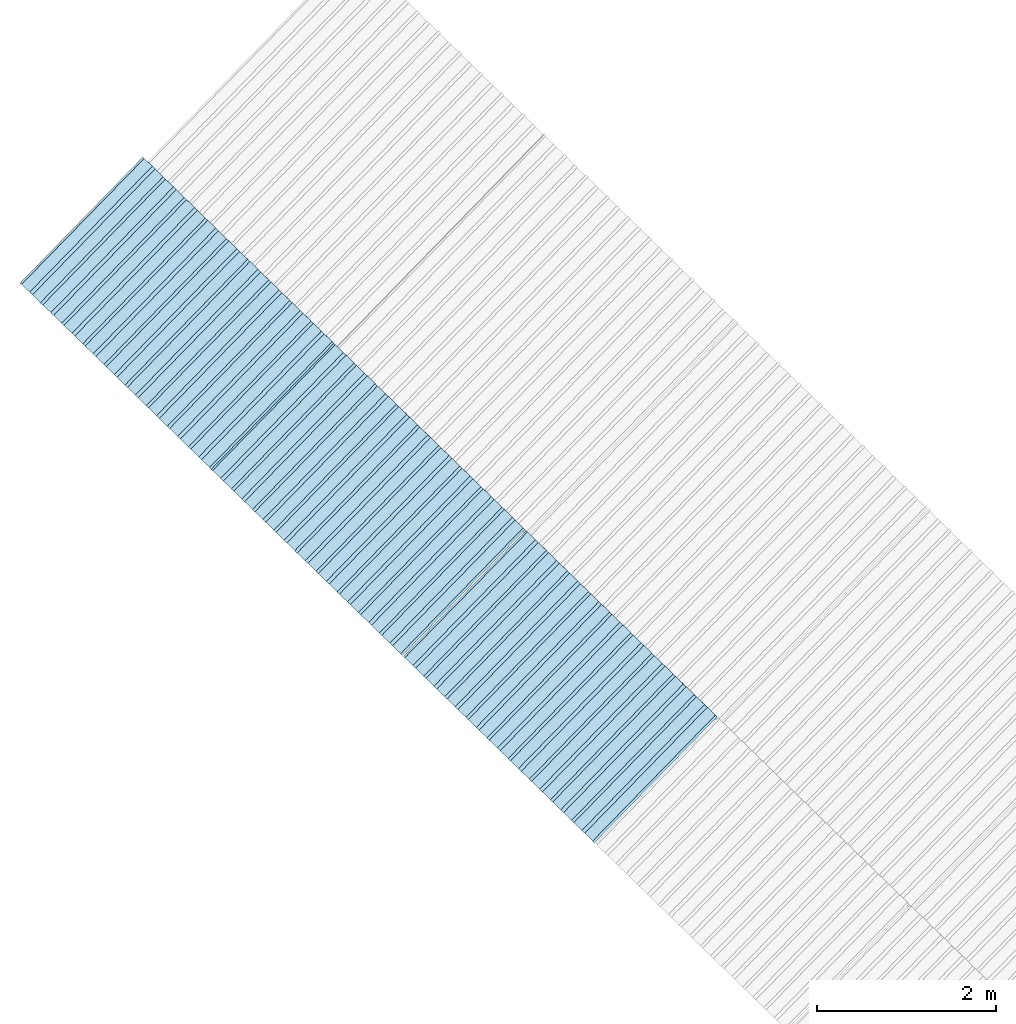
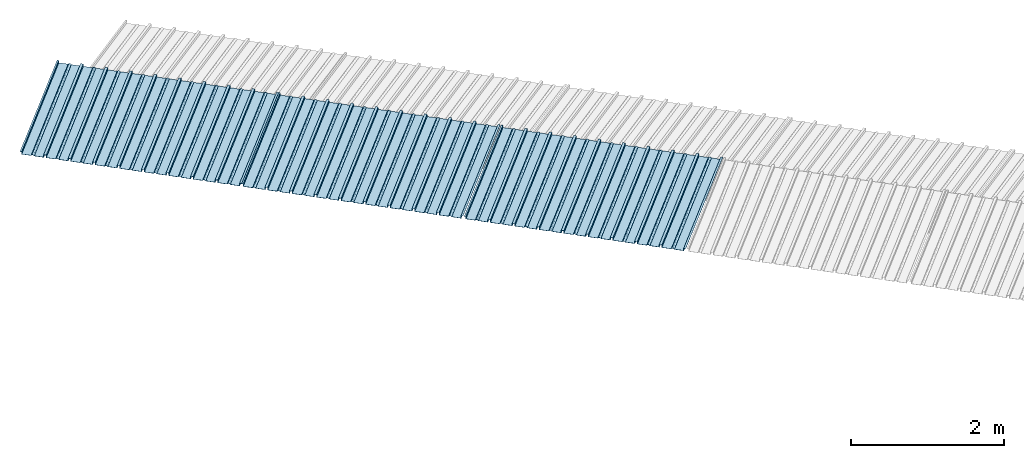
# One storey, part 6 of 8: 3 plates, 1 element without a shape of its own.
"""IFC4 building model written with IfcOpenShell, lengths in metres."""

from ifc_helpers import new_model, entity, si_unit, converted_unit, direction, frame, origin, place, context, subcontext, project, spatial, line, arc, indexed_curve, outline, extrude, source, transform, mapped, material, type_object, type_shapes, element, aggregate, save


model = new_model("IFC4")

# Units and contexts
model_context = context("Model", 3, precision=1e-05, world=origin(), true_north=direction((6.123233995736766e-17, 1.0)))
body_context = subcontext(model_context, "Body", "Model", "MODEL_VIEW")
ifc_project = project(units=[si_unit("LENGTHUNIT", "METRE"), si_unit("AREAUNIT", "SQUARE_METRE"), si_unit("VOLUMEUNIT", "CUBIC_METRE"), converted_unit("PLANEANGLEUNIT", "DEGREE", entity("IfcPlaneAngleMeasure", 0.017453292519943278), si_unit("PLANEANGLEUNIT", "RADIAN"), dimensions=[0, 0, 0, 0, 0, 0, 0])], contexts=[model_context])

# Site, building, storey
site_placement = place(None, frame((0.0, 0.0, 0.0), z_axis=(0.0, 0.0, 1.0), x_axis=(0.7160934825303189, -0.6980043870045516, 0.0)))
site = spatial("IfcSite", under=ifc_project, at=site_placement, CompositionType="ELEMENT")
building_placement = place(site_placement, origin())
building = spatial("IfcBuilding", under=site, at=building_placement, CompositionType="ELEMENT")
storey_placement = place(building_placement, frame((0.0, 0.0, -1.24)))
storey = spatial("IfcBuildingStorey", under=building, at=storey_placement, Name="Livello 5", CompositionType="ELEMENT", Elevation=-1.24)

# Roof, plates
curtain_wall_type = type_object("IfcCurtainWallType", Name="Vetrata Copertura 2", PredefinedType="NOTDEFINED")
roof_placement = place(storey_placement, frame((0.0, 0.0, 1.24)))
roof = element("IfcRoof", 1, at=roof_placement, inside=storey, type_object=curtain_wall_type, Name="Vetrata Copertura 2", ObjectType="Vetrata Copertura 2", PredefinedType="SHED_ROOF")
ifc_material = material(Name="Default")
plate_type_1 = type_object("IfcPlateType", Name="Pannello copertura:Pannello copertura", PredefinedType="CURTAIN_PANEL", material=ifc_material)
shared_shape_1 = source(origin(), body_context, "Body", "SweptSolid", [
    extrude(outline(indexed_curve([(1.339910560042256, -0.015785714285718594), (1.4699105600422562, -0.015785714285719003), (1.4699105600422562, 0.024214285714281004), (1.494919197675959, 0.02421428571428092), (1.494919197675959, 0.027214285714280917), (1.466910560042256, 0.027214285714281014), (1.466910560042256, -0.012785714285718995), (1.3417510978483753, -0.012785714285718492), (1.3199105600422556, 4.9134324369942785e-05), (1.2980700222361363, -0.012785714285718328), (1.1729105600422558, -0.01278571428571804), (1.1729105600422558, 0.02721428571428197), (1.136910560042256, 0.027214285714282097), (1.136910560042256, -0.012785714285717937), (1.0117510978483748, -0.01278571428571754), (0.9899105600422554, 4.913432437100935e-05), (0.968070022236136, -0.01278571428571726), (0.8429105600422558, -0.012785714285716971), (0.842910560042256, 0.027214285714283023), (0.8069105600422554, 0.027214285714283144), (0.8069105600422554, -0.01278571428571687), (0.6817510978483748, -0.012785714285716475), (0.6599105600422555, 4.9134324372075926e-05), (0.6380700222361361, -0.012785714285716196), (0.5129105600422553, -0.012785714285715915), (0.5129105600422554, 0.027214285714284105), (0.47691056004225557, 0.027214285714284227), (0.47691056004225557, -0.012785714285715804), (0.3517510978483749, -0.012785714285715427), (0.32991056004225544, 4.9134324373142496e-05), (0.3080700222361361, -0.012785714285715127), (0.18291056004225528, -0.012785714285714848), (0.18291056004225553, 0.027214285714285157), (0.1469105600422553, 0.02721428571428528), (0.14691056004225533, -0.012785714285714738), (0.021751097848374697, -0.01278571428571434), (-8.943995774469983e-05, 4.913432437420907e-05), (-0.021929977763864118, -0.01278571428571406), (-0.1470894399577447, -0.012785714285713783), (-0.14708943995774473, 0.02721428571428624), (-0.18308943995774493, 0.027214285714286364), (-0.1830894399577449, -0.012785714285713672), (-0.30824890215162537, -0.012785714285713215), (-0.33008943995774487, 4.9134324375275644e-05), (-0.3519299777638641, -0.012785714285712995), (-0.47708943995774494, -0.012785714285712714), (-0.4770894399577447, 0.02721428571428729), (-0.5130894399577449, 0.02721428571428741), (-0.5130894399577449, -0.012785714285712603), (-0.6382489021516256, -0.012785714285712207), (-0.6600894399577448, 4.9134324376342214e-05), (-0.6819299777638644, -0.012785714285711926), (-0.8070894399577453, -0.012785714285711647), (-0.807089439957745, 0.027214285714288373), (-0.843089439957745, 0.027214285714288494), (-0.8430894399577447, -0.012785714285711538), (-0.968248902151626, -0.012785714285711083), (-0.9900894399577453, 4.9134324377408785e-05), (-1.0119299777638646, -0.012785714285710861), (-1.1370894399577456, -0.012785714285710582), (-1.1370894399577451, 0.02721428571428942), (-1.1730894399577452, 0.027214285714289545), (-1.1730894399577454, -0.012785714285710473), (-1.2982489021516257, -0.012785714285710093), (-1.3200894399577452, 4.9134324378475355e-05), (-1.3419299777638647, -0.012785714285709794), (-1.4670894399577457, -0.012785714285709513), (-1.4670894399577454, 0.027214285714290503), (-1.490089439957745, 0.027214285714290586), (-1.490089439957745, 0.024214285714290556), (-1.4700894399577447, 0.02421428571429049), (-1.4700894399577449, -0.015785714285709514), (-1.3400894399577452, -0.015785714285709924), (-1.3200894399577452, -0.0029508656756215236), (-1.3000894399577452, -0.015785714285710063), (-1.170089439957745, -0.015785714285710472), (-1.1700894399577453, 0.024214285714289543), (-1.140089439957745, 0.02421428571428944), (-1.1400894399577455, -0.015785714285710583), (-1.0100894399577454, -0.015785714285710992), (-0.9900894399577453, -0.00295086567562259), (-0.9700894399577453, -0.015785714285711128), (-0.8400894399577448, -0.01578571428571154), (-0.8400894399577451, 0.024214285714288453), (-0.8100894399577452, 0.024214285714288356), (-0.8100894399577452, -0.015785714285711648), (-0.6800894399577451, -0.015785714285712012), (-0.6600894399577448, -0.0029508656756236573), (-0.6400894399577448, -0.015785714285712196), (-0.5100894399577451, -0.015785714285712606), (-0.5100894399577451, 0.024214285714287406), (-0.4800894399577449, 0.024214285714287305), (-0.4800894399577449, -0.015785714285712713), (-0.350089439957745, -0.01578571428571316), (-0.33008943995774487, -0.0029508656756247237), (-0.31008943995774485, -0.01578571428571326), (-0.1800894399577448, -0.015785714285713674), (-0.1800894399577448, 0.024214285714286323), (-0.1500894399577446, 0.02421428571428622), (-0.15008943995774485, -0.015785714285713782), (-0.020089439957744877, -0.015785714285714264), (-8.943995774473269e-05, -0.00295086567562579), (0.01991056004225521, -0.015785714285714323), (0.14991056004225545, -0.01578571428571474), (0.14991056004225542, 0.024214285714285272), (0.17991056004225567, 0.02421428571428517), (0.1799105600422554, -0.01578571428571485), (0.30991056004225526, -0.01578571428571532), (0.32991056004225544, -0.0029508656756268565), (0.3499105600422554, -0.015785714285715395), (0.47991056004225535, -0.015785714285715804), (0.47991056004225535, 0.02421428571428419), (0.5099105600422553, 0.02421428571428409), (0.5099105600422552, -0.015785714285715916), (0.6399105600422554, -0.015785714285716325), (0.6599105600422555, -0.002950865675627923), (0.6799105600422555, -0.01578571428571646), (0.8099105600422557, -0.015785714285716873), (0.8099105600422557, 0.02421428571428314), (0.8399105600422555, 0.02421428571428304), (0.8399105600422554, -0.015785714285716974), (0.9699105600422554, -0.015785714285717393), (0.9899105600422554, -0.0029508656756289894), (1.0099105600422555, -0.01578571428571753), (1.1399105600422557, -0.015785714285717938), (1.1399105600422557, 0.024214285714282077), (1.169910560042256, 0.024214285714281972), (1.1699105600422557, -0.01578571428571804), (1.2999105600422558, -0.01578571428571846), (1.3199105600422558, -0.0029508656756300567)], segments=[line(1, 2, 3, 4, 5, 6, 7, 8), arc(8, 9, 10), line(10, 11, 12, 13, 14, 15), arc(15, 16, 17), line(17, 18, 19, 20, 21, 22), arc(22, 23, 24), line(24, 25, 26, 27, 28, 29), arc(29, 30, 31), line(31, 32, 33, 34, 35, 36), arc(36, 37, 38), line(38, 39, 40, 41, 42, 43), arc(43, 44, 45), line(45, 46, 47, 48, 49, 50), arc(50, 51, 52), line(52, 53, 54, 55, 56, 57), arc(57, 58, 59), line(59, 60, 61, 62, 63, 64), arc(64, 65, 66), line(66, 67, 68, 69, 70, 71, 72, 73), arc(73, 74, 75), line(75, 76, 77, 78, 79, 80), arc(80, 81, 82), line(82, 83, 84, 85, 86, 87), arc(87, 88, 89), line(89, 90, 91, 92, 93, 94), arc(94, 95, 96), line(96, 97, 98, 99, 100, 101), arc(101, 102, 103), line(103, 104, 105, 106, 107, 108), arc(108, 109, 110), line(110, 111, 112, 113, 114, 115), arc(115, 116, 117), line(117, 118, 119, 120, 121, 122), arc(122, 123, 124), line(124, 125, 126, 127, 128, 129), arc(129, 130, 1)], self_intersect=False)), frame((8.080232403624576e-05, -0.015785714285719014, 0.0), z_axis=(0.0, 0.0, -1.0), x_axis=(1.0, 0.0, 0.0)), (0.0, 0.0, -1.0), 1.9691142879617602),
])
type_shapes(plate_type_1, [shared_shape_1])
plate_1_placement = place(roof_placement, frame((-26.21463516875178, -6.922854376535778, -1.0800000000000003), z_axis=(0.0, 0.9980594686585702, 0.0622679453729828), x_axis=(1.0, 0.0, 0.0)))
plate_1 = element("IfcPlate", 2, at=plate_1_placement, type_object=plate_type_1, material=ifc_material, Name="Pannello copertura:Pannello copertura", ObjectType="Pannello copertura:Pannello copertura", PredefinedType="CURTAIN_PANEL", context=body_context, shape_type="MappedRepresentation", body=[
    mapped(shared_shape_1, transform((0.0, 0.0, 0.0), scale=1.0)),
])
plate_type_2 = type_object("IfcPlateType", Name="Pannello copertura:Pannello copertura", PredefinedType="CURTAIN_PANEL", material=ifc_material)
shared_shape_2 = source(origin(), body_context, "Body", "SweptSolid", [
    extrude(outline(indexed_curve([(1.339910560042256, -0.015785714285718594), (1.4699105600422562, -0.015785714285719003), (1.4699105600422562, 0.024214285714281004), (1.494919197675959, 0.02421428571428092), (1.494919197675959, 0.027214285714280917), (1.466910560042256, 0.027214285714281014), (1.466910560042256, -0.012785714285718995), (1.3417510978483753, -0.012785714285718492), (1.3199105600422556, 4.9134324369942785e-05), (1.2980700222361363, -0.012785714285718328), (1.1729105600422558, -0.01278571428571804), (1.1729105600422558, 0.02721428571428197), (1.136910560042256, 0.027214285714282097), (1.136910560042256, -0.012785714285717937), (1.0117510978483748, -0.01278571428571754), (0.9899105600422554, 4.913432437100935e-05), (0.968070022236136, -0.01278571428571726), (0.8429105600422558, -0.012785714285716971), (0.842910560042256, 0.027214285714283023), (0.8069105600422554, 0.027214285714283144), (0.8069105600422554, -0.01278571428571687), (0.6817510978483748, -0.012785714285716475), (0.6599105600422555, 4.9134324372075926e-05), (0.6380700222361361, -0.012785714285716196), (0.5129105600422553, -0.012785714285715915), (0.5129105600422554, 0.027214285714284105), (0.47691056004225557, 0.027214285714284227), (0.47691056004225557, -0.012785714285715804), (0.3517510978483749, -0.012785714285715427), (0.32991056004225544, 4.9134324373142496e-05), (0.3080700222361361, -0.012785714285715127), (0.18291056004225528, -0.012785714285714848), (0.18291056004225553, 0.027214285714285157), (0.1469105600422553, 0.02721428571428528), (0.14691056004225533, -0.012785714285714738), (0.021751097848374697, -0.01278571428571434), (-8.943995774469983e-05, 4.913432437420907e-05), (-0.021929977763864118, -0.01278571428571406), (-0.1470894399577447, -0.012785714285713783), (-0.14708943995774473, 0.02721428571428624), (-0.18308943995774493, 0.027214285714286364), (-0.1830894399577449, -0.012785714285713672), (-0.30824890215162537, -0.012785714285713215), (-0.33008943995774487, 4.9134324375275644e-05), (-0.3519299777638641, -0.012785714285712995), (-0.47708943995774494, -0.012785714285712714), (-0.4770894399577447, 0.02721428571428729), (-0.5130894399577449, 0.02721428571428741), (-0.5130894399577449, -0.012785714285712603), (-0.6382489021516256, -0.012785714285712207), (-0.6600894399577448, 4.9134324376342214e-05), (-0.6819299777638644, -0.012785714285711926), (-0.8070894399577453, -0.012785714285711647), (-0.807089439957745, 0.027214285714288373), (-0.843089439957745, 0.027214285714288494), (-0.8430894399577447, -0.012785714285711538), (-0.968248902151626, -0.012785714285711083), (-0.9900894399577453, 4.9134324377408785e-05), (-1.0119299777638646, -0.012785714285710861), (-1.1370894399577456, -0.012785714285710582), (-1.1370894399577451, 0.02721428571428942), (-1.1730894399577452, 0.027214285714289545), (-1.1730894399577454, -0.012785714285710473), (-1.2982489021516257, -0.012785714285710093), (-1.3200894399577452, 4.9134324378475355e-05), (-1.3419299777638647, -0.012785714285709794), (-1.4670894399577457, -0.012785714285709513), (-1.4670894399577454, 0.027214285714290503), (-1.490089439957745, 0.027214285714290586), (-1.490089439957745, 0.024214285714290556), (-1.4700894399577447, 0.02421428571429049), (-1.4700894399577449, -0.015785714285709514), (-1.3400894399577452, -0.015785714285709924), (-1.3200894399577452, -0.0029508656756215236), (-1.3000894399577452, -0.015785714285710063), (-1.170089439957745, -0.015785714285710472), (-1.1700894399577453, 0.024214285714289543), (-1.140089439957745, 0.02421428571428944), (-1.1400894399577455, -0.015785714285710583), (-1.0100894399577454, -0.015785714285710992), (-0.9900894399577453, -0.00295086567562259), (-0.9700894399577453, -0.015785714285711128), (-0.8400894399577448, -0.01578571428571154), (-0.8400894399577451, 0.024214285714288453), (-0.8100894399577452, 0.024214285714288356), (-0.8100894399577452, -0.015785714285711648), (-0.6800894399577451, -0.015785714285712012), (-0.6600894399577448, -0.0029508656756236573), (-0.6400894399577448, -0.015785714285712196), (-0.5100894399577451, -0.015785714285712606), (-0.5100894399577451, 0.024214285714287406), (-0.4800894399577449, 0.024214285714287305), (-0.4800894399577449, -0.015785714285712713), (-0.350089439957745, -0.01578571428571316), (-0.33008943995774487, -0.0029508656756247237), (-0.31008943995774485, -0.01578571428571326), (-0.1800894399577448, -0.015785714285713674), (-0.1800894399577448, 0.024214285714286323), (-0.1500894399577446, 0.02421428571428622), (-0.15008943995774485, -0.015785714285713782), (-0.020089439957744877, -0.015785714285714264), (-8.943995774473269e-05, -0.00295086567562579), (0.01991056004225521, -0.015785714285714323), (0.14991056004225545, -0.01578571428571474), (0.14991056004225542, 0.024214285714285272), (0.17991056004225567, 0.02421428571428517), (0.1799105600422554, -0.01578571428571485), (0.30991056004225526, -0.01578571428571532), (0.32991056004225544, -0.0029508656756268565), (0.3499105600422554, -0.015785714285715395), (0.47991056004225535, -0.015785714285715804), (0.47991056004225535, 0.02421428571428419), (0.5099105600422553, 0.02421428571428409), (0.5099105600422552, -0.015785714285715916), (0.6399105600422554, -0.015785714285716325), (0.6599105600422555, -0.002950865675627923), (0.6799105600422555, -0.01578571428571646), (0.8099105600422557, -0.015785714285716873), (0.8099105600422557, 0.02421428571428314), (0.8399105600422555, 0.02421428571428304), (0.8399105600422554, -0.015785714285716974), (0.9699105600422554, -0.015785714285717393), (0.9899105600422554, -0.0029508656756289894), (1.0099105600422555, -0.01578571428571753), (1.1399105600422557, -0.015785714285717938), (1.1399105600422557, 0.024214285714282077), (1.169910560042256, 0.024214285714281972), (1.1699105600422557, -0.01578571428571804), (1.2999105600422558, -0.01578571428571846), (1.3199105600422558, -0.0029508656756300567)], segments=[line(1, 2, 3, 4, 5, 6, 7, 8), arc(8, 9, 10), line(10, 11, 12, 13, 14, 15), arc(15, 16, 17), line(17, 18, 19, 20, 21, 22), arc(22, 23, 24), line(24, 25, 26, 27, 28, 29), arc(29, 30, 31), line(31, 32, 33, 34, 35, 36), arc(36, 37, 38), line(38, 39, 40, 41, 42, 43), arc(43, 44, 45), line(45, 46, 47, 48, 49, 50), arc(50, 51, 52), line(52, 53, 54, 55, 56, 57), arc(57, 58, 59), line(59, 60, 61, 62, 63, 64), arc(64, 65, 66), line(66, 67, 68, 69, 70, 71, 72, 73), arc(73, 74, 75), line(75, 76, 77, 78, 79, 80), arc(80, 81, 82), line(82, 83, 84, 85, 86, 87), arc(87, 88, 89), line(89, 90, 91, 92, 93, 94), arc(94, 95, 96), line(96, 97, 98, 99, 100, 101), arc(101, 102, 103), line(103, 104, 105, 106, 107, 108), arc(108, 109, 110), line(110, 111, 112, 113, 114, 115), arc(115, 116, 117), line(117, 118, 119, 120, 121, 122), arc(122, 123, 124), line(124, 125, 126, 127, 128, 129), arc(129, 130, 1)], self_intersect=False)), frame((8.080232403624576e-05, -0.015785714285719014, 0.0), z_axis=(0.0, 0.0, -1.0), x_axis=(1.0, 0.0, 0.0)), (0.0, 0.0, -1.0), 1.9691142879617602),
])
type_shapes(plate_type_2, [shared_shape_2])
plate_2_placement = place(roof_placement, frame((-23.23213518620344, -6.922854376535778, -1.0800000000000003), z_axis=(0.0, 0.9980594686585702, 0.0622679453729828), x_axis=(1.0, 0.0, 0.0)))
plate_2 = element("IfcPlate", 3, at=plate_2_placement, type_object=plate_type_2, material=ifc_material, Name="Pannello copertura:Pannello copertura", ObjectType="Pannello copertura:Pannello copertura", PredefinedType="CURTAIN_PANEL", context=body_context, shape_type="MappedRepresentation", body=[
    mapped(shared_shape_2, transform((0.0, 0.0, 0.0), scale=1.0)),
])
plate_type_3 = type_object("IfcPlateType", Name="Pannello copertura:Pannello copertura", PredefinedType="CURTAIN_PANEL", material=ifc_material)
shared_shape_3 = source(origin(), body_context, "Body", "SweptSolid", [
    extrude(outline(indexed_curve([(1.339910560042256, -0.015785714285718594), (1.4699105600422562, -0.015785714285719003), (1.4699105600422562, 0.024214285714281004), (1.494919197675959, 0.02421428571428092), (1.494919197675959, 0.027214285714280917), (1.466910560042256, 0.027214285714281014), (1.466910560042256, -0.012785714285718995), (1.3417510978483753, -0.012785714285718492), (1.3199105600422556, 4.9134324369942785e-05), (1.2980700222361363, -0.012785714285718328), (1.1729105600422558, -0.01278571428571804), (1.1729105600422558, 0.02721428571428197), (1.136910560042256, 0.027214285714282097), (1.136910560042256, -0.012785714285717937), (1.0117510978483748, -0.01278571428571754), (0.9899105600422554, 4.913432437100935e-05), (0.968070022236136, -0.01278571428571726), (0.8429105600422558, -0.012785714285716971), (0.842910560042256, 0.027214285714283023), (0.8069105600422554, 0.027214285714283144), (0.8069105600422554, -0.01278571428571687), (0.6817510978483748, -0.012785714285716475), (0.6599105600422555, 4.9134324372075926e-05), (0.6380700222361361, -0.012785714285716196), (0.5129105600422553, -0.012785714285715915), (0.5129105600422554, 0.027214285714284105), (0.47691056004225557, 0.027214285714284227), (0.47691056004225557, -0.012785714285715804), (0.3517510978483749, -0.012785714285715427), (0.32991056004225544, 4.9134324373142496e-05), (0.3080700222361361, -0.012785714285715127), (0.18291056004225528, -0.012785714285714848), (0.18291056004225553, 0.027214285714285157), (0.1469105600422553, 0.02721428571428528), (0.14691056004225533, -0.012785714285714738), (0.021751097848374697, -0.01278571428571434), (-8.943995774469983e-05, 4.913432437420907e-05), (-0.021929977763864118, -0.01278571428571406), (-0.1470894399577447, -0.012785714285713783), (-0.14708943995774473, 0.02721428571428624), (-0.18308943995774493, 0.027214285714286364), (-0.1830894399577449, -0.012785714285713672), (-0.30824890215162537, -0.012785714285713215), (-0.33008943995774487, 4.9134324375275644e-05), (-0.3519299777638641, -0.012785714285712995), (-0.47708943995774494, -0.012785714285712714), (-0.4770894399577447, 0.02721428571428729), (-0.5130894399577449, 0.02721428571428741), (-0.5130894399577449, -0.012785714285712603), (-0.6382489021516256, -0.012785714285712207), (-0.6600894399577448, 4.9134324376342214e-05), (-0.6819299777638644, -0.012785714285711926), (-0.8070894399577453, -0.012785714285711647), (-0.807089439957745, 0.027214285714288373), (-0.843089439957745, 0.027214285714288494), (-0.8430894399577447, -0.012785714285711538), (-0.968248902151626, -0.012785714285711083), (-0.9900894399577453, 4.9134324377408785e-05), (-1.0119299777638646, -0.012785714285710861), (-1.1370894399577456, -0.012785714285710582), (-1.1370894399577451, 0.02721428571428942), (-1.1730894399577452, 0.027214285714289545), (-1.1730894399577454, -0.012785714285710473), (-1.2982489021516257, -0.012785714285710093), (-1.3200894399577452, 4.9134324378475355e-05), (-1.3419299777638647, -0.012785714285709794), (-1.4670894399577457, -0.012785714285709513), (-1.4670894399577454, 0.027214285714290503), (-1.490089439957745, 0.027214285714290586), (-1.490089439957745, 0.024214285714290556), (-1.4700894399577447, 0.02421428571429049), (-1.4700894399577449, -0.015785714285709514), (-1.3400894399577452, -0.015785714285709924), (-1.3200894399577452, -0.0029508656756215236), (-1.3000894399577452, -0.015785714285710063), (-1.170089439957745, -0.015785714285710472), (-1.1700894399577453, 0.024214285714289543), (-1.140089439957745, 0.02421428571428944), (-1.1400894399577455, -0.015785714285710583), (-1.0100894399577454, -0.015785714285710992), (-0.9900894399577453, -0.00295086567562259), (-0.9700894399577453, -0.015785714285711128), (-0.8400894399577448, -0.01578571428571154), (-0.8400894399577451, 0.024214285714288453), (-0.8100894399577452, 0.024214285714288356), (-0.8100894399577452, -0.015785714285711648), (-0.6800894399577451, -0.015785714285712012), (-0.6600894399577448, -0.0029508656756236573), (-0.6400894399577448, -0.015785714285712196), (-0.5100894399577451, -0.015785714285712606), (-0.5100894399577451, 0.024214285714287406), (-0.4800894399577449, 0.024214285714287305), (-0.4800894399577449, -0.015785714285712713), (-0.350089439957745, -0.01578571428571316), (-0.33008943995774487, -0.0029508656756247237), (-0.31008943995774485, -0.01578571428571326), (-0.1800894399577448, -0.015785714285713674), (-0.1800894399577448, 0.024214285714286323), (-0.1500894399577446, 0.02421428571428622), (-0.15008943995774485, -0.015785714285713782), (-0.020089439957744877, -0.015785714285714264), (-8.943995774473269e-05, -0.00295086567562579), (0.01991056004225521, -0.015785714285714323), (0.14991056004225545, -0.01578571428571474), (0.14991056004225542, 0.024214285714285272), (0.17991056004225567, 0.02421428571428517), (0.1799105600422554, -0.01578571428571485), (0.30991056004225526, -0.01578571428571532), (0.32991056004225544, -0.0029508656756268565), (0.3499105600422554, -0.015785714285715395), (0.47991056004225535, -0.015785714285715804), (0.47991056004225535, 0.02421428571428419), (0.5099105600422553, 0.02421428571428409), (0.5099105600422552, -0.015785714285715916), (0.6399105600422554, -0.015785714285716325), (0.6599105600422555, -0.002950865675627923), (0.6799105600422555, -0.01578571428571646), (0.8099105600422557, -0.015785714285716873), (0.8099105600422557, 0.02421428571428314), (0.8399105600422555, 0.02421428571428304), (0.8399105600422554, -0.015785714285716974), (0.9699105600422554, -0.015785714285717393), (0.9899105600422554, -0.0029508656756289894), (1.0099105600422555, -0.01578571428571753), (1.1399105600422557, -0.015785714285717938), (1.1399105600422557, 0.024214285714282077), (1.169910560042256, 0.024214285714281972), (1.1699105600422557, -0.01578571428571804), (1.2999105600422558, -0.01578571428571846), (1.3199105600422558, -0.0029508656756300567)], segments=[line(1, 2, 3, 4, 5, 6, 7, 8), arc(8, 9, 10), line(10, 11, 12, 13, 14, 15), arc(15, 16, 17), line(17, 18, 19, 20, 21, 22), arc(22, 23, 24), line(24, 25, 26, 27, 28, 29), arc(29, 30, 31), line(31, 32, 33, 34, 35, 36), arc(36, 37, 38), line(38, 39, 40, 41, 42, 43), arc(43, 44, 45), line(45, 46, 47, 48, 49, 50), arc(50, 51, 52), line(52, 53, 54, 55, 56, 57), arc(57, 58, 59), line(59, 60, 61, 62, 63, 64), arc(64, 65, 66), line(66, 67, 68, 69, 70, 71, 72, 73), arc(73, 74, 75), line(75, 76, 77, 78, 79, 80), arc(80, 81, 82), line(82, 83, 84, 85, 86, 87), arc(87, 88, 89), line(89, 90, 91, 92, 93, 94), arc(94, 95, 96), line(96, 97, 98, 99, 100, 101), arc(101, 102, 103), line(103, 104, 105, 106, 107, 108), arc(108, 109, 110), line(110, 111, 112, 113, 114, 115), arc(115, 116, 117), line(117, 118, 119, 120, 121, 122), arc(122, 123, 124), line(124, 125, 126, 127, 128, 129), arc(129, 130, 1)], self_intersect=False)), frame((8.080232403624576e-05, -0.015785714285719014, 0.0), z_axis=(0.0, 0.0, -1.0), x_axis=(1.0, 0.0, 0.0)), (0.0, 0.0, -1.0), 1.9691142879617602),
])
type_shapes(plate_type_3, [shared_shape_3])
plate_3_placement = place(roof_placement, frame((-20.232130117528893, -6.922854376535778, -1.0800000000000003), z_axis=(0.0, 0.9980594686585702, 0.0622679453729828), x_axis=(1.0, 0.0, 0.0)))
plate_3 = element("IfcPlate", 4, at=plate_3_placement, type_object=plate_type_3, material=ifc_material, Name="Pannello copertura:Pannello copertura", ObjectType="Pannello copertura:Pannello copertura", PredefinedType="CURTAIN_PANEL", context=body_context, shape_type="MappedRepresentation", body=[
    mapped(shared_shape_3, transform((0.0, 0.0, 0.0), scale=1.0)),
])
aggregate(roof, [plate_1, plate_2, plate_3])

save(model, "model.ifc")
